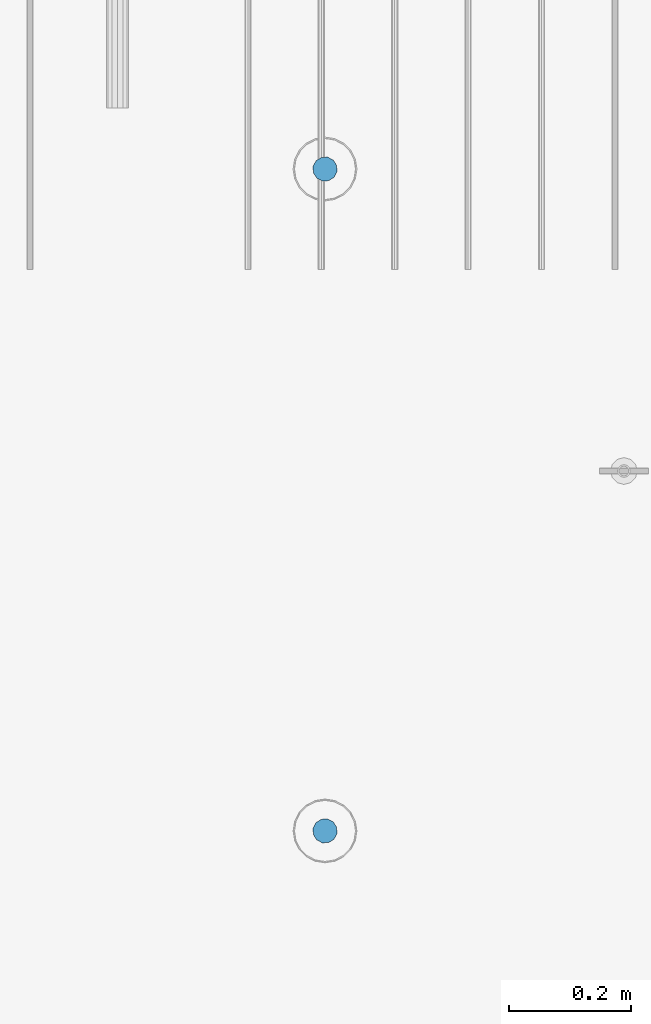
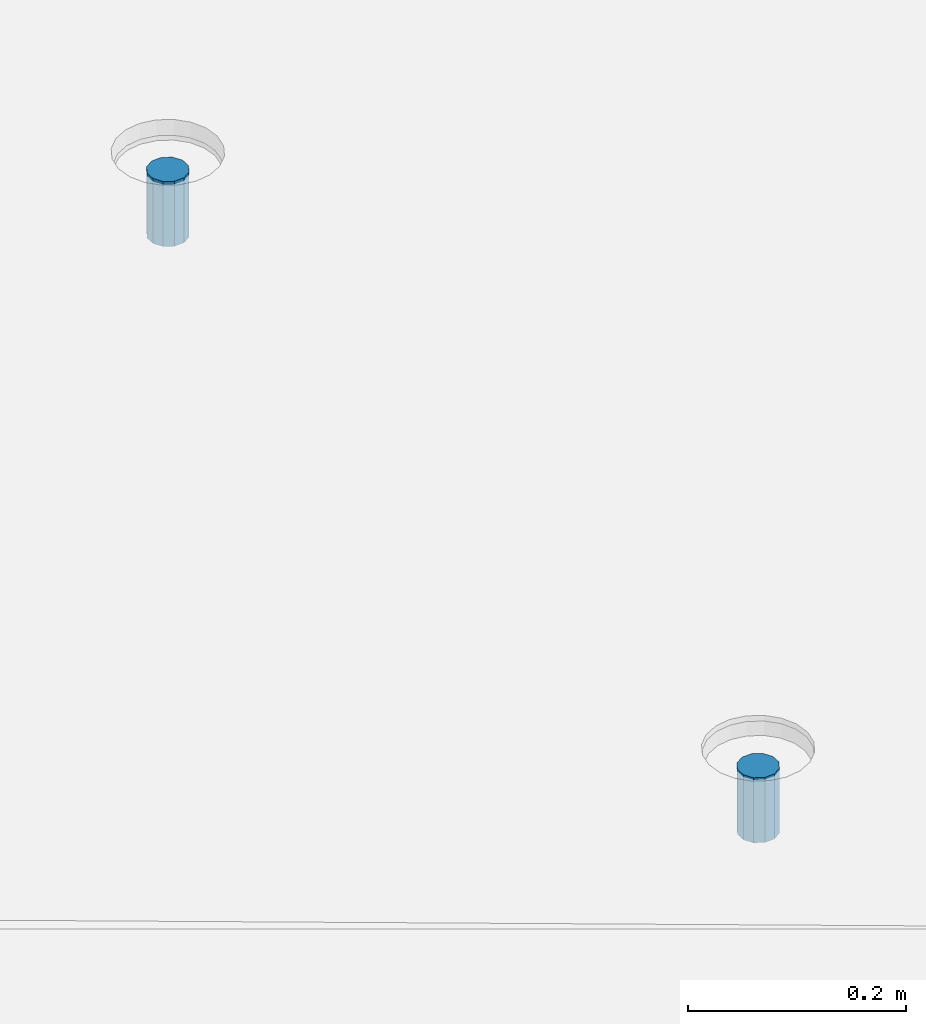
# One storey, part 13 of 153: 2 columns, 3 elements without a shape of their own.
"""IFC2X3 building model written with IfcOpenShell, lengths in millimetres."""

from ifc_helpers import new_model, si_unit, frame, origin_with_axes, place, context, subcontext, project, spatial, faceted_brep, material, type_object, element, aggregate, save


model = new_model("IFC2X3")

# Units and contexts
model_context = context("Model", 3, precision=1e-05, world=origin_with_axes())
body_context = subcontext(model_context, "Body", "Model", "MODEL_VIEW")
ifc_project = project(units=[si_unit("LENGTHUNIT", "METRE", prefix="MILLI"), si_unit("AREAUNIT", "SQUARE_METRE"), si_unit("VOLUMEUNIT", "CUBIC_METRE"), si_unit("MASSUNIT", "GRAM", prefix="KILO"), si_unit("TIMEUNIT", "SECOND"), si_unit("PLANEANGLEUNIT", "RADIAN"), si_unit("SOLIDANGLEUNIT", "STERADIAN"), si_unit("THERMODYNAMICTEMPERATUREUNIT", "DEGREE_CELSIUS"), si_unit("LUMINOUSINTENSITYUNIT", "LUMEN")], contexts=[model_context])

# Site, building, storey
site_placement = place(None, origin_with_axes())
site = spatial("IfcSite", under=ifc_project, at=site_placement, CompositionType="ELEMENT")
building_placement = place(site_placement, origin_with_axes())
building = spatial("IfcBuilding", under=site, at=building_placement, CompositionType="ELEMENT")
storey_placement = place(building_placement, origin_with_axes())
storey = spatial("IfcBuildingStorey", under=building, at=storey_placement, Name="8", CompositionType="ELEMENT", Elevation=0.0)

# Assemblies, columns
assembly_1_placement = place(storey_placement, origin_with_axes())
assembly_1 = element("IfcElementAssembly", 1, at=assembly_1_placement, inside=storey, AssemblyPlace="NOTDEFINED", PredefinedType="REINFORCEMENT_UNIT")
assembly_2_placement = place(assembly_1_placement, origin_with_axes())
assembly_2 = element("IfcElementAssembly", 2, at=assembly_2_placement, Name="Steel Assembly", AssemblyPlace="NOTDEFINED", PredefinedType="RIGID_FRAME")
ifc_material = material(Name="STEEL/Steel_Undefined")
column_type = type_object("IfcColumnType", Name="D40", PredefinedType="NOTDEFINED")
column_1_placement = place(assembly_2_placement, frame((29359.9950440812, 7079.99280261383, 102624.0), z_axis=(-0.74071949690495, 0.671814428913794, 2.84800000335798e-06), x_axis=(3.26300002209467e-06, -6.4100000499712e-07, 0.999999999994471)))
column_1 = element("IfcColumn", 3, at=column_1_placement, type_object=column_type, material=ifc_material, Name="R-Group R", ObjectType="D40", context=body_context, shape_type="Brep", body=[
    faceted_brep([(0.0, -20.0, 0.0), (0.0, -17.3205080756888, -10.0), (73.0, -17.3205080756852, -9.99999999999636), (73.0, -19.9999999999964, 3.63797880709171e-12), (0.0, -10.0, -17.3205080756888), (73.0, -10.0, -17.3205080756834), (0.0, 0.0, -20.0), (73.0, 3.63797880709171e-12, -19.9999999999964), (0.0, 10.0, -17.3205080756888), (73.0, 10.0000000000036, -17.3205080756834), (0.0, 17.3205080756888, -10.0), (73.0, 17.3205080756925, -9.99999999999818), (0.0, 20.0, 0.0), (73.0, 20.0, 3.63797880709171e-12), (0.0, 17.3205080756888, 10.0), (73.0, 17.3205080756888, 10.0000000000036), (0.0, 10.0, 17.3205080756888), (73.0, 10.0000000000036, 17.3205080756961), (0.0, 0.0, 20.0), (73.0, 3.63797880709171e-12, 20.0000000000036), (0.0, -10.0, 17.3205080756888), (73.0, -9.99999999999636, 17.3205080756925), (0.0, -17.3205080756888, 10.0), (73.0, -17.3205080756852, 10.0000000000055)], [[[0, 1, 2, 3]], [[1, 4, 5, 2]], [[4, 6, 7, 5]], [[6, 8, 9, 7]], [[8, 10, 11, 9]], [[10, 12, 13, 11]], [[12, 14, 15, 13]], [[14, 16, 17, 15]], [[16, 18, 19, 17]], [[18, 20, 21, 19]], [[20, 22, 23, 21]], [[22, 0, 3, 23]], [[5, 7, 9, 11, 13, 15, 17, 19, 21, 23, 3, 2]], [[22, 20, 18, 16, 14, 12, 10, 8, 6, 4, 1, 0]]]),
])
aggregate(assembly_2, [column_1])
assembly_3_placement = place(assembly_1_placement, origin_with_axes())
assembly_3 = element("IfcElementAssembly", 4, at=assembly_3_placement, Name="Steel Assembly", AssemblyPlace="NOTDEFINED", PredefinedType="RIGID_FRAME")
aggregate(assembly_1, [assembly_2, assembly_3])
column_2_placement = place(assembly_3_placement, frame((29359.9950440812, 5994.99280261383, 102613.0), z_axis=(-0.74071949690495, 0.671814428913794, 2.84800000335798e-06), x_axis=(3.26300002209467e-06, -6.4100000499712e-07, 0.999999999994471)))
column_2 = element("IfcColumn", 5, at=column_2_placement, type_object=column_type, material=ifc_material, Name="R-Group R", ObjectType="D40", context=body_context, shape_type="Brep", body=[
    faceted_brep([(0.0, -20.0, 0.0), (0.0, -17.3205080756888, -10.0), (73.0, -17.3205080756852, -9.99999999999636), (73.0, -19.9999999999964, 3.63797880709171e-12), (0.0, -10.0, -17.3205080756888), (73.0, -10.0, -17.3205080756834), (0.0, 0.0, -20.0), (73.0, 3.63797880709171e-12, -19.9999999999964), (0.0, 10.0, -17.3205080756888), (73.0, 10.0000000000036, -17.3205080756834), (0.0, 17.3205080756888, -10.0), (73.0, 17.3205080756925, -9.99999999999818), (0.0, 20.0, 0.0), (73.0, 20.0, 3.63797880709171e-12), (0.0, 17.3205080756888, 10.0), (73.0, 17.3205080756888, 10.0000000000036), (0.0, 10.0, 17.3205080756888), (73.0, 10.0000000000036, 17.3205080756961), (0.0, 0.0, 20.0), (73.0, 3.63797880709171e-12, 20.0000000000036), (0.0, -10.0, 17.3205080756888), (73.0, -9.99999999999636, 17.3205080756925), (0.0, -17.3205080756888, 10.0), (73.0, -17.3205080756852, 10.0000000000055)], [[[0, 1, 2, 3]], [[1, 4, 5, 2]], [[4, 6, 7, 5]], [[6, 8, 9, 7]], [[8, 10, 11, 9]], [[10, 12, 13, 11]], [[12, 14, 15, 13]], [[14, 16, 17, 15]], [[16, 18, 19, 17]], [[18, 20, 21, 19]], [[20, 22, 23, 21]], [[22, 0, 3, 23]], [[5, 7, 9, 11, 13, 15, 17, 19, 21, 23, 3, 2]], [[22, 20, 18, 16, 14, 12, 10, 8, 6, 4, 1, 0]]]),
])
aggregate(assembly_3, [column_2])

save(model, "model.ifc")
